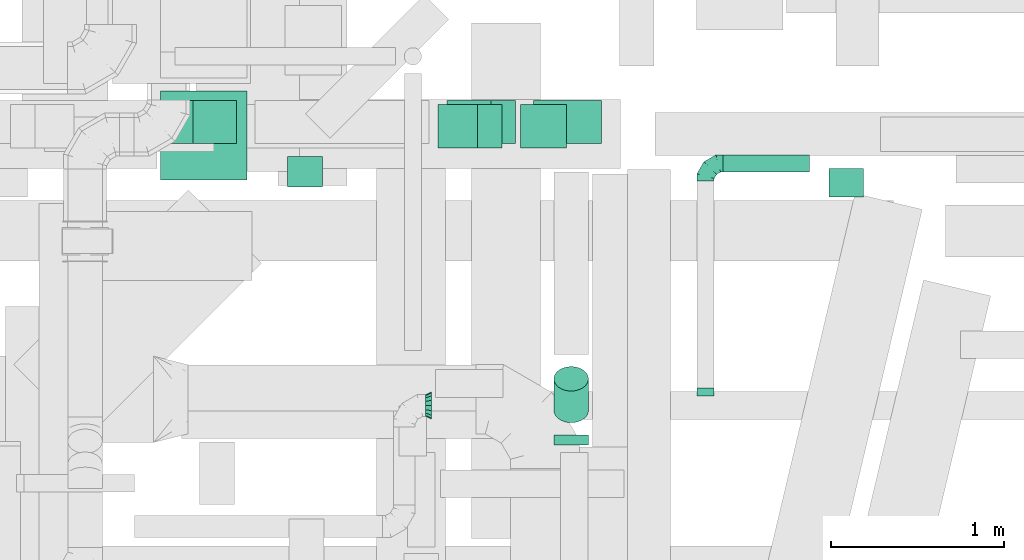
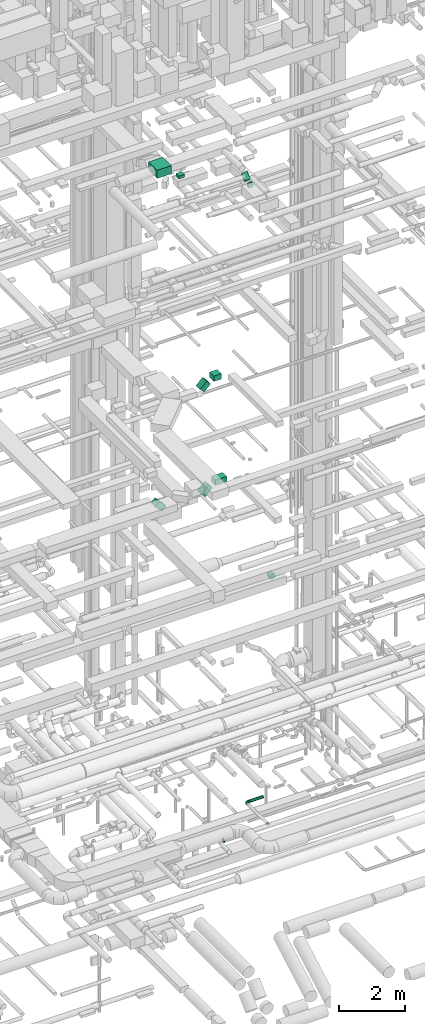
# One storey, part 167 of 337: 11 flow segments, 3 flow fittings.
"""IFC2X3 building model written with IfcOpenShell, lengths in millimetres."""

from ifc_helpers import new_model, entity, si_unit, converted_unit, derived_unit, direction, frame, frame_2d, origin, origin_2d_with_axis, place, context, subcontext, project, spatial, rectangle, circle, extrude, faceted_brep, source, transform, mapped, material, type_object, type_shapes, element, save


model = new_model("IFC2X3")

# Units and contexts
model_context = context("Model", 3, precision=0.01, world=origin(), true_north=direction((6.12303176911189e-17, 1.0)))
body_context = subcontext(model_context, "Body", "Model", "MODEL_VIEW")
ifc_project = project(units=[si_unit("LENGTHUNIT", "METRE", prefix="MILLI"), si_unit("AREAUNIT", "SQUARE_METRE"), si_unit("VOLUMEUNIT", "CUBIC_METRE"), converted_unit("PLANEANGLEUNIT", "DEGREE", entity("IfcRatioMeasure", 0.0174532925199433), si_unit("PLANEANGLEUNIT", "RADIAN"), dimensions=[0, 0, 0, 0, 0, 0, 0]), si_unit("MASSUNIT", "GRAM", prefix="KILO"), derived_unit("MASSDENSITYUNIT", [(si_unit("MASSUNIT", "GRAM", prefix="KILO"), 1), (si_unit("LENGTHUNIT", "METRE"), -3)]), derived_unit("MOMENTOFINERTIAUNIT", [(si_unit("LENGTHUNIT", "METRE"), 4)]), si_unit("TIMEUNIT", "SECOND"), si_unit("FREQUENCYUNIT", "HERTZ"), si_unit("THERMODYNAMICTEMPERATUREUNIT", "DEGREE_CELSIUS"), derived_unit("THERMALTRANSMITTANCEUNIT", [(si_unit("MASSUNIT", "GRAM", prefix="KILO"), 1), (si_unit("THERMODYNAMICTEMPERATUREUNIT", "KELVIN"), -1), (si_unit("TIMEUNIT", "SECOND"), -3)]), derived_unit("VOLUMETRICFLOWRATEUNIT", [(si_unit("LENGTHUNIT", "METRE"), 3), (si_unit("TIMEUNIT", "SECOND"), -1)]), derived_unit("MASSFLOWRATEUNIT", [(si_unit("MASSUNIT", "GRAM", prefix="KILO"), 1), (si_unit("TIMEUNIT", "SECOND"), -1)]), derived_unit("ROTATIONALFREQUENCYUNIT", [(si_unit("TIMEUNIT", "SECOND"), -1)]), si_unit("ELECTRICCURRENTUNIT", "AMPERE"), si_unit("ELECTRICVOLTAGEUNIT", "VOLT"), si_unit("POWERUNIT", "WATT"), si_unit("FORCEUNIT", "NEWTON", prefix="KILO"), si_unit("ILLUMINANCEUNIT", "LUX"), si_unit("LUMINOUSFLUXUNIT", "LUMEN"), si_unit("LUMINOUSINTENSITYUNIT", "CANDELA"), derived_unit("USERDEFINED", [(si_unit("MASSUNIT", "GRAM", prefix="KILO"), -1), (si_unit("LENGTHUNIT", "METRE"), -2), (si_unit("TIMEUNIT", "SECOND"), 3), (si_unit("LUMINOUSFLUXUNIT", "LUMEN"), 1)]), derived_unit("LINEARVELOCITYUNIT", [(si_unit("LENGTHUNIT", "METRE"), 1), (si_unit("TIMEUNIT", "SECOND"), -1)]), si_unit("PRESSUREUNIT", "PASCAL"), derived_unit("USERDEFINED", [(si_unit("LENGTHUNIT", "METRE"), -2), (si_unit("MASSUNIT", "GRAM", prefix="KILO"), 1), (si_unit("TIMEUNIT", "SECOND"), -2)]), derived_unit("LINEARFORCEUNIT", [(si_unit("MASSUNIT", "GRAM", prefix="KILO"), 1), (si_unit("LENGTHUNIT", "METRE"), 1), (si_unit("TIMEUNIT", "SECOND"), -2), (si_unit("LENGTHUNIT", "METRE"), -1)]), derived_unit("PLANARFORCEUNIT", [(si_unit("MASSUNIT", "GRAM", prefix="KILO"), 1), (si_unit("LENGTHUNIT", "METRE"), 1), (si_unit("TIMEUNIT", "SECOND"), -2), (si_unit("LENGTHUNIT", "METRE"), -2)])], contexts=[model_context])

# Site, building, storey
site_placement = place(None, origin())
site = spatial("IfcSite", under=ifc_project, at=site_placement, CompositionType="ELEMENT")
building_placement = place(site_placement, origin())
building = spatial("IfcBuilding", under=site, at=building_placement, CompositionType="ELEMENT")
storey_placement = place(building_placement, origin())
storey = spatial("IfcBuildingStorey", under=building, at=storey_placement, CompositionType="ELEMENT", Elevation=0.0)

# Flow segments
duct_segment_type_1 = type_object("IfcDuctSegmentType", PredefinedType="NOTDEFINED")
flow_segment_1_placement = place(storey_placement, frame((51622.14, 5600.81, 18803.1)))
element("IfcFlowSegment", 1, at=flow_segment_1_placement, inside=storey, type_object=duct_segment_type_1, context=body_context, shape_type="SweptSolid", body=[
    extrude(rectangle(XDim=200.000000000003, YDim=250.000000000001, at=origin_2d_with_axis()), frame((70.71, 125.0, 70.71), z_axis=(0.707106781186488, 0.0, 0.707106781186607), x_axis=(-0.707106781186607, 0.0, 0.707106781186488)), (0.0, 0.0, 1.0), 322.390693496514),
])
flow_segment_2_placement = place(storey_placement, frame((52097.6, 5600.81, 19075.0)))
element("IfcFlowSegment", 2, at=flow_segment_2_placement, inside=storey, type_object=duct_segment_type_1, context=body_context, shape_type="SweptSolid", body=[
    extrude(rectangle(XDim=267.624099467677, YDim=250.000000000001, at=origin_2d_with_axis()), frame((133.81, 125.0, 0.0), z_axis=(0.0, 0.0, 1.0), x_axis=(-1.0, 0.0, 0.0)), (0.0, 0.0, 1.0), 200.000000000002),
])
flow_segment_3_placement = place(storey_placement, frame((50061.24, 5625.44, 14902.51)))
element("IfcFlowSegment", 3, at=flow_segment_3_placement, inside=storey, type_object=duct_segment_type_1, context=body_context, shape_type="SweptSolid", body=[
    extrude(rectangle(XDim=199.999999999989, YDim=250.000000000001, at=origin_2d_with_axis()), frame((70.71, 125.0, 324.26), z_axis=(0.707106781186569, 0.0, -0.707106781186526), x_axis=(0.707106781186526, 0.0, 0.707106781186569)), (0.0, 0.0, 1.0), 358.578643762721),
])
flow_segment_4_placement = place(storey_placement, frame((52174.84, 5625.44, 15200.0)))
element("IfcFlowSegment", 4, at=flow_segment_4_placement, inside=storey, type_object=duct_segment_type_1, context=body_context, shape_type="SweptSolid", body=[
    extrude(rectangle(XDim=391.166609406764, YDim=250.000000000001, at=origin_2d_with_axis()), frame((195.58, 125.0, 0.0), z_axis=(0.0, 0.0, 1.0), x_axis=(-1.0, 0.0, 0.0)), (0.0, 0.0, 1.0), 200.000000000002),
])
flow_segment_5_placement = place(storey_placement, frame((51673.8, 5625.44, 14902.51)))
element("IfcFlowSegment", 5, at=flow_segment_5_placement, inside=storey, type_object=duct_segment_type_1, context=body_context, shape_type="SweptSolid", body=[
    extrude(rectangle(XDim=200.000000000004, YDim=249.999999999999, at=frame_2d((0.0, 0.0), x_axis=(0.0, 1.0))), frame((70.71, 125.0, 70.71), z_axis=(0.707106781186493, 0.0, 0.707106781186602), x_axis=(0.0, 1.0, 0.0)), (0.0, 0.0, 1.0), 358.578643762715),
])
flow_segment_6_placement = place(storey_placement, frame((50016.44, 5415.67, 27400.0)))
element("IfcFlowSegment", 6, at=flow_segment_6_placement, inside=storey, type_object=duct_segment_type_1, context=body_context, shape_type="SweptSolid", body=[
    extrude(rectangle(XDim=515.118888314273, YDim=499.999999999999, at=origin_2d_with_axis()), frame((250.0, 257.56, 0.0), z_axis=(0.0, 0.0, 1.0), x_axis=(0.0, -1.0, 0.0)), (0.0, 0.0, 1.0), 300.000000000001),
])
flow_segment_7_placement = place(storey_placement, frame((50751.67, 5373.68, 27150.0)))
element("IfcFlowSegment", 7, at=flow_segment_7_placement, inside=storey, type_object=duct_segment_type_1, context=body_context, shape_type="SweptSolid", body=[
    extrude(rectangle(XDim=176.446609406717, YDim=199.999999999998, at=origin_2d_with_axis()), frame((100.0, 88.22, 0.0), z_axis=(0.0, 0.0, 1.0), x_axis=(0.0, -1.0, 0.0)), (0.0, 0.0, 1.0), 100.000000000003),
])
duct_segment_type_2 = type_object("IfcDuctSegmentType", PredefinedType="NOTDEFINED")
flow_segment_8_placement = place(storey_placement, frame((53880.33, 5315.54, 11298.4)))
element("IfcFlowSegment", 8, at=flow_segment_8_placement, inside=storey, type_object=duct_segment_type_2, context=body_context, shape_type="SweptSolid", body=[
    extrude(circle(Radius=100.0, at=origin_2d_with_axis()), frame((101.6, 0.0, 101.6), z_axis=(0.0, 1.0, 0.0), x_axis=(-1.0, 0.0, 0.0)), (0.0, 0.0, 1.0), 165.000000000071),
])
flow_segment_9_placement = place(storey_placement, frame((52289.77, 3883.41, 27148.4)))
element("IfcFlowSegment", 9, at=flow_segment_9_placement, inside=storey, type_object=duct_segment_type_2, context=body_context, shape_type="SweptSolid", body=[
    extrude(circle(Radius=100.0, at=origin_2d_with_axis()), frame((101.6, 0.0, 101.6), z_axis=(0.0, 1.0, 0.0), x_axis=(-1.0, 0.0, 0.0)), (0.0, 0.0, 1.0), 57.1572875254181),
])
flow_segment_10_placement = place(storey_placement, frame((52289.77, 4009.68, 27236.27)))
element("IfcFlowSegment", 10, at=flow_segment_10_placement, inside=storey, type_object=duct_segment_type_2, context=body_context, shape_type="SweptSolid", body=[
    extrude(circle(Radius=100.0, at=origin_2d_with_axis()), frame((101.6, 72.31, 72.31), z_axis=(0.0, 0.70710678118653, 0.707106781186565), x_axis=(-1.0, 0.0, 0.0)), (0.0, 0.0, 1.0), 258.578643762676),
])
flow_segment_11_placement = place(storey_placement, frame((53268.86, 5458.69, 3198.4)))
element("IfcFlowSegment", 11, at=flow_segment_11_placement, inside=storey, type_object=duct_segment_type_2, context=body_context, shape_type="SweptSolid", body=[
    extrude(circle(Radius=50.0, at=origin_2d_with_axis()), frame((0.0, 51.6, 51.6), z_axis=(1.0, 0.0, 0.0), x_axis=(0.0, -1.0, 0.0)), (0.0, 0.0, 1.0), 500.000000000008),
])

# Flow fittings
ifc_material = material()
duct_fitting_type_1 = type_object("IfcDuctFittingType", PredefinedType="NOTDEFINED", material=ifc_material)
shared_shape_1 = source(origin(), body_context, "Body", "Brep", [
    faceted_brep([(-100.0, 0.0, -50.0), (-100.0, -12.94, -48.3), (-100.0, -25.0, -43.3), (-100.0, -35.36, -35.36), (-100.0, -43.3, -25.0), (-100.0, -48.3, -12.94), (-100.0, -50.0, 0.0), (-100.0, -48.3, 12.94), (-100.0, -43.3, 25.0), (-100.0, -35.36, 35.36), (-100.0, -25.0, 43.3), (-100.0, -12.94, 48.3), (-100.0, 0.0, 50.0), (-100.0, 12.94, 48.3), (-100.0, 25.0, 43.3), (-100.0, 35.36, 35.36), (-100.0, 43.3, 25.0), (-100.0, 48.3, 12.94), (-100.0, 50.0, 0.0), (-100.0, 48.3, -12.94), (-100.0, 43.3, -25.0), (-100.0, 35.36, -35.36), (-100.0, 25.0, -43.3), (-100.0, 12.94, -48.3), (-76.67, 12.94, 48.3), (-79.9, 25.0, 43.3), (-73.21, 0.0, 50.0), (-82.68, 35.36, 35.36), (-86.15, 48.3, 12.94), (-86.6, 50.0, 0.0), (-84.81, 43.3, 25.0), (-84.81, 43.3, -25.0), (-82.68, 35.36, -35.36), (-86.15, 48.3, -12.94), (-76.67, 12.94, -48.3), (-73.21, 0.0, -50.0), (-79.9, 25.0, -43.3), (-69.74, -12.94, -48.3), (-66.51, -25.0, -43.3), (-63.73, -35.36, -35.36), (-61.6, -43.3, -25.0), (-60.26, -48.3, -12.94), (-59.81, -50.0, 0.0), (-60.26, -48.3, 12.94), (-61.6, -43.3, 25.0), (-63.73, -35.36, 35.36), (-66.51, -25.0, 43.3), (-69.74, -12.94, 48.3), (-36.27, 36.27, 48.3), (-45.1, 45.1, 43.3), (-26.79, 26.79, 50.0), (-52.68, 52.68, 35.36), (-58.49, 58.49, 25.0), (-62.15, 62.15, 12.94), (-63.4, 63.4, 0.0), (-62.15, 62.15, -12.94), (-58.49, 58.49, -25.0), (-52.68, 52.68, -35.36), (-36.27, 36.27, -48.3), (-26.79, 26.79, -50.0), (-45.1, 45.1, -43.3), (-17.32, 17.32, -48.3), (-8.49, 8.49, -43.3), (-0.91, 0.91, -35.36), (4.9, -4.9, -25.0), (8.56, -8.56, -12.94), (9.81, -9.81, 0.0), (8.56, -8.56, 12.94), (4.9, -4.9, 25.0), (-0.91, 0.91, 35.36), (-8.49, 8.49, 43.3), (-17.32, 17.32, 48.3), (-12.94, 76.67, 48.3), (-25.0, 79.9, 43.3), (0.0, 73.21, 50.0), (-35.36, 82.68, 35.36), (-43.3, 84.81, 25.0), (-48.3, 86.15, 12.94), (-50.0, 86.6, 0.0), (-48.3, 86.15, -12.94), (-43.3, 84.81, -25.0), (-35.36, 82.68, -35.36), (-12.94, 76.67, -48.3), (0.0, 73.21, -50.0), (-25.0, 79.9, -43.3), (12.94, 69.74, -48.3), (25.0, 66.51, -43.3), (35.36, 63.73, -35.36), (43.3, 61.6, -25.0), (48.3, 60.26, -12.94), (50.0, 59.81, 0.0), (48.3, 60.26, 12.94), (43.3, 61.6, 25.0), (35.36, 63.73, 35.36), (25.0, 66.51, 43.3), (12.94, 69.74, 48.3), (-12.94, 100.0, -48.3), (-25.0, 100.0, -43.3), (-35.36, 100.0, -35.36), (-43.3, 100.0, -25.0), (-48.3, 100.0, -12.94), (-50.0, 100.0, 0.0), (-48.3, 100.0, 12.94), (-43.3, 100.0, 25.0), (-35.36, 100.0, 35.36), (-25.0, 100.0, 43.3), (-12.94, 100.0, 48.3), (0.0, 100.0, 50.0), (12.94, 100.0, 48.3), (25.0, 100.0, 43.3), (35.36, 100.0, 35.36), (43.3, 100.0, 25.0), (48.3, 100.0, 12.94), (50.0, 100.0, 0.0), (48.3, 100.0, -12.94), (43.3, 100.0, -25.0), (35.36, 100.0, -35.36), (25.0, 100.0, -43.3), (12.94, 100.0, -48.3), (0.0, 100.0, -50.0)], [[[0, 1, 2, 3, 4, 5, 6, 7, 8, 9, 10, 11, 12, 13, 14, 15, 16, 17, 18, 19, 20, 21, 22, 23]], [[24, 25, 14, 13]], [[26, 24, 13, 12]], [[14, 25, 27, 15]], [[28, 29, 18, 17]], [[30, 28, 17, 16]], [[15, 27, 30, 16]], [[20, 31, 32, 21]], [[33, 31, 20, 19]], [[18, 29, 33, 19]], [[34, 35, 0, 23]], [[36, 34, 23, 22]], [[32, 36, 22, 21]], [[2, 1, 37, 38]], [[3, 2, 38, 39]], [[0, 35, 37, 1]], [[5, 4, 40, 41]], [[6, 5, 41, 42]], [[3, 39, 40, 4]], [[6, 42, 43, 7]], [[7, 43, 44, 8]], [[8, 44, 45, 9]], [[10, 46, 47, 11]], [[11, 47, 26, 12]], [[10, 9, 45, 46]], [[48, 49, 25, 24]], [[50, 48, 24, 26]], [[27, 25, 49, 51]], [[52, 53, 28, 30]], [[51, 52, 30, 27]], [[29, 28, 53, 54]], [[55, 56, 31, 33]], [[54, 55, 33, 29]], [[57, 32, 31, 56]], [[58, 59, 35, 34]], [[60, 58, 34, 36]], [[57, 60, 36, 32]], [[37, 35, 59, 61]], [[38, 37, 61, 62]], [[39, 38, 62, 63]], [[41, 40, 64, 65]], [[42, 41, 65, 66]], [[63, 64, 40, 39]], [[43, 42, 66, 67]], [[44, 43, 67, 68]], [[68, 69, 45, 44]], [[46, 45, 69, 70]], [[47, 46, 70, 71]], [[26, 47, 71, 50]], [[72, 73, 49, 48]], [[74, 72, 48, 50]], [[51, 49, 73, 75]], [[76, 77, 53, 52]], [[75, 76, 52, 51]], [[54, 53, 77, 78]], [[79, 80, 56, 55]], [[78, 79, 55, 54]], [[81, 57, 56, 80]], [[82, 83, 59, 58]], [[84, 82, 58, 60]], [[81, 84, 60, 57]], [[61, 59, 83, 85]], [[62, 61, 85, 86]], [[63, 62, 86, 87]], [[65, 64, 88, 89]], [[66, 65, 89, 90]], [[87, 88, 64, 63]], [[67, 66, 90, 91]], [[68, 67, 91, 92]], [[92, 93, 69, 68]], [[70, 69, 93, 94]], [[71, 70, 94, 95]], [[50, 71, 95, 74]], [[96, 97, 98, 99, 100, 101, 102, 103, 104, 105, 106, 107, 108, 109, 110, 111, 112, 113, 114, 115, 116, 117, 118, 119]], [[72, 74, 107, 106]], [[73, 72, 106, 105]], [[75, 73, 105, 104]], [[77, 76, 103, 102]], [[78, 77, 102, 101]], [[75, 104, 103, 76]], [[78, 101, 100, 79]], [[79, 100, 99, 80]], [[80, 99, 98, 81]], [[96, 119, 83, 82]], [[97, 96, 82, 84]], [[84, 81, 98, 97]], [[83, 119, 118, 85]], [[85, 118, 117, 86]], [[86, 117, 116, 87]], [[88, 115, 114, 89]], [[89, 114, 113, 90]], [[87, 116, 115, 88]], [[91, 90, 113, 112]], [[92, 91, 112, 111]], [[93, 92, 111, 110]], [[95, 94, 109, 108]], [[74, 95, 108, 107]], [[110, 109, 94, 93]]]),
])
type_shapes(duct_fitting_type_1, [shared_shape_1])
flow_fitting_1_placement = place(storey_placement, frame((53168.86, 5510.29, 3250.0), z_axis=(0.0, 0.0, 1.0), x_axis=(-1.0, 0.0, 0.0)))
element("IfcFlowFitting", 12, at=flow_fitting_1_placement, inside=storey, type_object=duct_fitting_type_1, material=ifc_material, context=body_context, shape_type="MappedRepresentation", body=[
    mapped(shared_shape_1, transform((0.0, 0.0, 0.0), scale=1.0)),
])
duct_fitting_type_2 = type_object("IfcDuctFittingType", PredefinedType="NOTDEFINED", material=ifc_material)
shared_shape_2 = source(origin(), body_context, "Body", "Brep", [
    faceted_brep([(35.0, -57.74, 23.92), (35.0, -60.12, 11.96), (35.0, -62.5, 0.0), (35.0, -60.12, -11.96), (35.0, -57.74, -23.92), (35.0, -50.97, -34.06), (35.0, -44.19, -44.19), (35.0, -34.06, -50.97), (35.0, -23.92, -57.74), (35.0, -11.96, -60.12), (35.0, 0.0, -62.5), (35.0, 11.96, -60.12), (35.0, 23.92, -57.74), (35.0, 34.06, -50.97), (35.0, 44.19, -44.19), (35.0, 50.97, -34.06), (35.0, 57.74, -23.92), (35.0, 60.12, -11.96), (35.0, 62.5, 0.0), (35.0, 60.12, 11.96), (35.0, 57.74, 23.92), (35.0, 50.97, 34.06), (35.0, 44.19, 44.19), (35.0, 34.06, 50.97), (35.0, 23.92, 57.74), (35.0, 11.96, 60.12), (35.0, 0.0, 62.5), (35.0, -11.96, 60.12), (35.0, -23.92, 57.74), (35.0, -34.06, 50.97), (35.0, -44.19, 44.19), (35.0, -50.97, 34.06), (0.0, -80.0, 0.0), (0.0, -77.45, 12.81), (0.0, -73.91, 30.61), (0.0, -65.24, 43.59), (0.0, -56.57, 56.57), (0.0, -43.59, 65.24), (0.0, -30.61, 73.91), (0.0, -12.81, 77.45), (0.0, 0.0, 80.0), (0.0, 12.81, 77.45), (0.0, 30.61, 73.91), (0.0, 43.59, 65.24), (0.0, 56.57, 56.57), (0.0, 65.24, 43.59), (0.0, 73.91, 30.61), (0.0, 77.45, 12.81), (0.0, 80.0, 0.0), (0.0, 77.45, -12.81), (0.0, 73.91, -30.61), (0.0, 65.24, -43.59), (0.0, 56.57, -56.57), (0.0, 43.59, -65.24), (0.0, 30.61, -73.91), (0.0, 12.81, -77.45), (0.0, 0.0, -80.0), (0.0, -12.81, -77.45), (0.0, -30.61, -73.91), (0.0, -43.59, -65.24), (0.0, -56.57, -56.57), (0.0, -65.24, -43.59), (0.0, -73.91, -30.61), (0.0, -77.45, -12.81)], [[[0, 1, 2, 3, 4, 5, 6, 7, 8, 9, 10, 11, 12, 13, 14, 15, 16, 17, 18, 19, 20, 21, 22, 23, 24, 25, 26, 27, 28, 29, 30, 31]], [[32, 33, 34, 35, 36, 37, 38, 39, 40, 41, 42, 43, 44, 45, 46, 47, 48, 49, 50, 51, 52, 53, 54, 55, 56, 57, 58, 59, 60, 61, 62, 63]], [[24, 23, 22, 44, 43, 42]], [[20, 46, 45, 44, 22, 21]], [[42, 41, 40, 26, 25, 24]], [[47, 46, 20, 19, 18, 48]], [[0, 31, 30, 36, 35, 34]], [[28, 38, 37, 36, 30, 29]], [[34, 33, 32, 2, 1, 0]], [[39, 38, 28, 27, 26, 40]], [[8, 7, 6, 60, 59, 58]], [[4, 62, 61, 60, 6, 5]], [[58, 57, 56, 10, 9, 8]], [[63, 62, 4, 3, 2, 32]], [[16, 15, 14, 52, 51, 50]], [[12, 54, 53, 52, 14, 13]], [[50, 49, 48, 18, 17, 16]], [[55, 54, 12, 11, 10, 56]]]),
])
type_shapes(duct_fitting_type_2, [shared_shape_2])
flow_fitting_2_placement = place(storey_placement, frame((51585.0, 4110.29, 3250.0), z_axis=(0.0, 0.0, 1.0), x_axis=(-1.0, 0.0, 0.0)))
element("IfcFlowFitting", 13, at=flow_fitting_2_placement, inside=storey, type_object=duct_fitting_type_2, material=ifc_material, context=body_context, shape_type="MappedRepresentation", body=[
    mapped(shared_shape_2, transform((0.0, 0.0, 0.0), scale=1.0)),
])
duct_fitting_type_3 = type_object("IfcDuctFittingType", PredefinedType="NOTDEFINED", material=ifc_material)
shared_shape_3 = source(origin(), body_context, "Body", "Brep", [
    faceted_brep([(20.0, 12.94, -48.3), (20.0, 25.0, -43.3), (20.0, 35.36, -35.36), (20.0, 43.3, -25.0), (20.0, 48.3, -12.94), (20.0, 50.0, 0.0), (20.0, 48.3, 12.94), (20.0, 43.3, 25.0), (20.0, 35.36, 35.36), (20.0, 25.0, 43.3), (20.0, 12.94, 48.3), (20.0, 0.0, 50.0), (20.0, -12.94, 48.3), (20.0, -25.0, 43.3), (20.0, -35.36, 35.36), (20.0, -43.3, 25.0), (20.0, -48.3, 12.94), (20.0, -50.0, 0.0), (20.0, -48.3, -12.94), (20.0, -43.3, -25.0), (20.0, -35.36, -35.36), (20.0, -25.0, -43.3), (20.0, -12.94, -48.3), (20.0, 0.0, -50.0), (0.0, 0.0, 50.0), (0.0, 12.94, 48.3), (-23.65, 12.94, 48.3), (-23.65, 0.0, 50.0), (0.0, 25.0, 43.3), (-23.65, 25.0, 43.3), (0.0, 35.36, 35.36), (-23.65, 35.36, 35.36), (0.0, 43.3, 25.0), (0.0, 48.3, 12.94), (-23.65, 48.3, 12.94), (-23.65, 43.3, 25.0), (0.0, 50.0, 0.0), (-23.65, 50.0, 0.0), (0.0, 48.3, -12.94), (-23.65, 48.3, -12.94), (0.0, 43.3, -25.0), (-23.65, 43.3, -25.0), (0.0, 35.36, -35.36), (-23.65, 35.36, -35.36), (0.0, 25.0, -43.3), (0.0, 12.94, -48.3), (-23.65, 12.94, -48.3), (-23.65, 25.0, -43.3), (0.0, 0.0, -50.0), (-23.65, 0.0, -50.0), (0.0, -12.94, -48.3), (-23.65, -12.94, -48.3), (0.0, -25.0, -43.3), (-23.65, -25.0, -43.3), (0.0, -35.36, -35.36), (-23.65, -35.36, -35.36), (0.0, -43.3, -25.0), (0.0, -48.3, -12.94), (-23.65, -48.3, -12.94), (-23.65, -43.3, -25.0), (0.0, -50.0, 0.0), (-23.65, -50.0, 0.0), (0.0, -48.3, 12.94), (-23.65, -48.3, 12.94), (0.0, -43.3, 25.0), (-23.65, -43.3, 25.0), (0.0, -35.36, 35.36), (-23.65, -35.36, 35.36), (0.0, -25.0, 43.3), (0.0, -12.94, 48.3), (-23.65, -12.94, 48.3), (-23.65, -25.0, 43.3)], [[[0, 1, 2, 3, 4, 5, 6, 7, 8, 9, 10, 11, 12, 13, 14, 15, 16, 17, 18, 19, 20, 21, 22, 23]], [[24, 11, 10, 25, 26, 27]], [[25, 10, 9, 28, 29, 26]], [[28, 9, 8, 30, 31, 29]], [[32, 7, 6, 33, 34, 35]], [[33, 6, 5, 36, 37, 34]], [[30, 8, 7, 32, 35, 31]], [[36, 5, 4, 38, 39, 37]], [[38, 4, 3, 40, 41, 39]], [[40, 3, 2, 42, 43, 41]], [[44, 1, 0, 45, 46, 47]], [[45, 0, 23, 48, 49, 46]], [[42, 2, 1, 44, 47, 43]], [[48, 23, 22, 50, 51, 49]], [[50, 22, 21, 52, 53, 51]], [[52, 21, 20, 54, 55, 53]], [[56, 19, 18, 57, 58, 59]], [[57, 18, 17, 60, 61, 58]], [[54, 20, 19, 56, 59, 55]], [[60, 17, 16, 62, 63, 61]], [[62, 16, 15, 64, 65, 63]], [[64, 15, 14, 66, 67, 65]], [[68, 13, 12, 69, 70, 71]], [[69, 12, 11, 24, 27, 70]], [[66, 14, 13, 68, 71, 67]], [[49, 51, 53, 55, 59, 58, 61, 63, 65, 67, 71, 70, 27, 26, 29, 31, 35, 34, 37, 39, 41, 43, 47, 46]]]),
])
type_shapes(duct_fitting_type_3, [shared_shape_3])
flow_fitting_3_placement = place(storey_placement, frame((53168.86, 4190.29, 3250.0), z_axis=(0.0, 0.0, -1.0), x_axis=(0.0, 1.0, 0.0)))
element("IfcFlowFitting", 14, at=flow_fitting_3_placement, inside=storey, type_object=duct_fitting_type_3, material=ifc_material, context=body_context, shape_type="MappedRepresentation", body=[
    mapped(shared_shape_3, transform((0.0, 0.0, 0.0), scale=1.0)),
])

save(model, "model.ifc")
